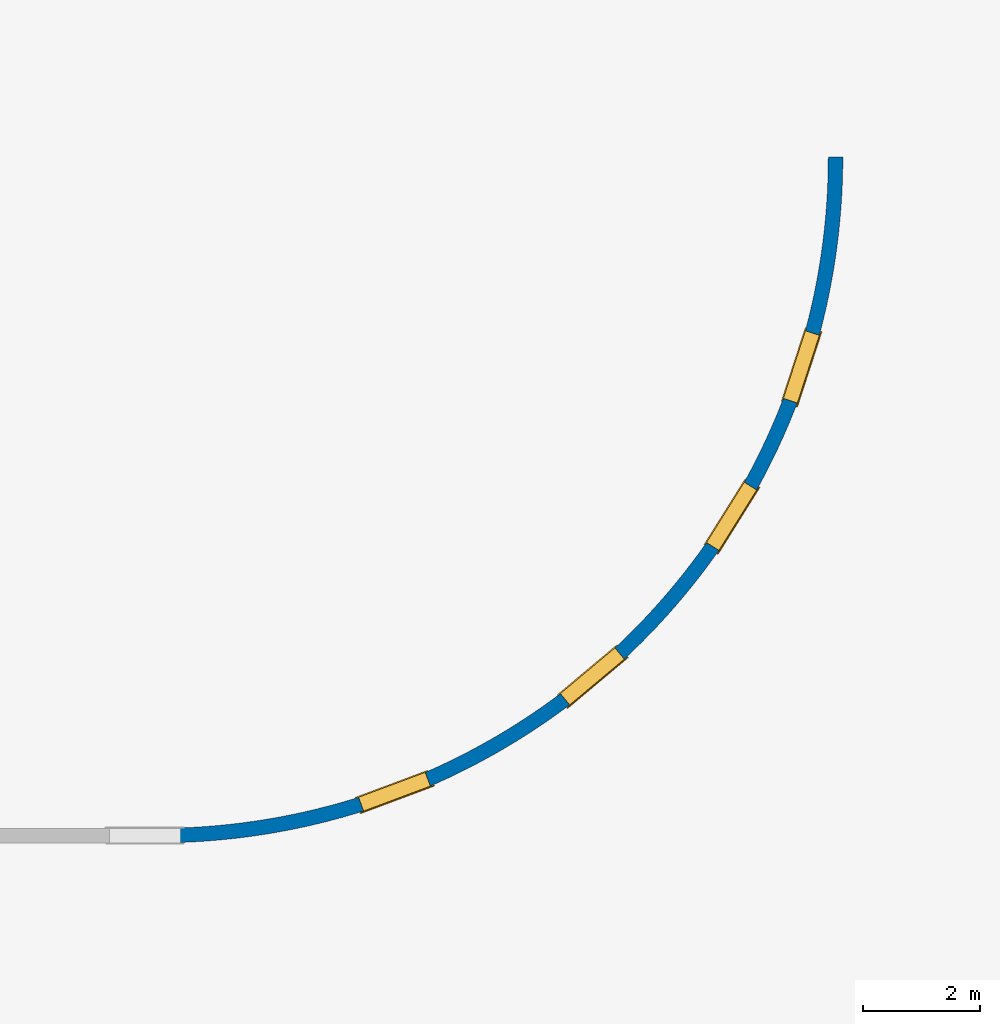
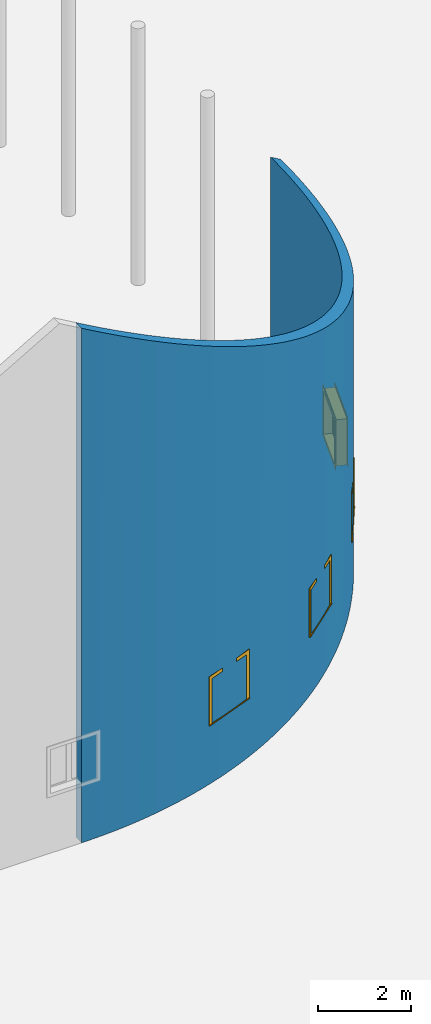
# One storey, part 9 of 39: 4 windows, 1 wall, 4 openings.
"""IFC2X3 building model written with IfcOpenShell, lengths in millimetres."""

from ifc_helpers import new_model, entity, si_unit, converted_unit, derived_unit, direction, frame, frame_2d, origin, origin_2d_with_axis, place, context, subcontext, project, spatial, polyline, circle_curve, parameter, trimmed, segment, composite_curve, rectangle, outline, extrude, clip, bounded_halfspace, source, transform, mapped, material, material_list, layer, layer_set, layer_usage, type_object, type_shapes, element, fill, save


model = new_model("IFC2X3")

# Units and contexts
model_context = context("Model", 3, precision=1e-06, world=origin(), true_north=direction((2.0, 6.12303176911189e-17, 1.0)))
context_of_model = context(None, 3, precision=1e-06, world=origin(), true_north=direction((2.0, 6.12303176911189e-17, 1.0)))
body_context = subcontext(model_context, "Body", "Model", "MODEL_VIEW")
ifc_project = project(units=[si_unit("LENGTHUNIT", "METRE", prefix="MILLI"), si_unit("AREAUNIT", "SQUARE_METRE", prefix="MILLI"), si_unit("VOLUMEUNIT", "CUBIC_METRE", prefix="MILLI"), converted_unit("PLANEANGLEUNIT", "DEGREE", entity("IfcRatioMeasure", 0.0174532925199433), si_unit("PLANEANGLEUNIT", "RADIAN"), dimensions=[0, 0, 0, 0, 0, 0, 0]), si_unit("MASSUNIT", "GRAM", prefix="KILO"), si_unit("TIMEUNIT", "SECOND"), si_unit("THERMODYNAMICTEMPERATUREUNIT", "KELVIN"), derived_unit("THERMALTRANSMITTANCEUNIT", [(si_unit("MASSUNIT", "GRAM", prefix="KILO"), 1), (si_unit("THERMODYNAMICTEMPERATUREUNIT", "KELVIN"), -1), (si_unit("TIMEUNIT", "SECOND"), -3)]), derived_unit("VOLUMETRICFLOWRATEUNIT", [(si_unit("LENGTHUNIT", "METRE"), 3), (si_unit("TIMEUNIT", "SECOND"), -1)])], contexts=[model_context, context_of_model])

# Site, building, storey
site_placement = place(None, origin())
site = spatial("IfcSite", under=ifc_project, at=site_placement, CompositionType="ELEMENT")
building_placement = place(site_placement, origin())
building = spatial("IfcBuilding", under=site, at=building_placement, CompositionType="ELEMENT")
storey_placement = place(building_placement, frame((0.0, 0.0, 4000.0)))
storey = spatial("IfcBuildingStorey", under=building, at=storey_placement, Name="Level 2", CompositionType="ELEMENT", Elevation=4000.0)

# Wall, openings, windows
ifc_material_1 = material(Name="Concrete - Cast In Situ")
ifc_layer = layer(ifc_material_1, 250.0)
ifc_layer_set = layer_set([ifc_layer], Name="Basic Wall:Structure wall")
ifc_layer_usage = layer_usage(ifc_layer_set, "AXIS2", "NEGATIVE", 125.0)
wall_type = type_object("IfcWallType", Name="Basic Wall:Structure wall", PredefinedType="STANDARD", material=ifc_layer_set)
wall_placement = place(storey_placement, frame((-80947.4247632614, -15130.5876773198, 362.0), z_axis=(0.0, 0.0, 1.0), x_axis=(-1.0, 0.0, 0.0)))
wall = element("IfcWallStandardCase", 1, at=wall_placement, inside=storey, type_object=wall_type, material=ifc_layer_usage, Name="Basic Wall:Structure wall", ObjectType="Basic Wall:Structure wall", context=body_context, shape_type="Clipping", body=[
    clip(extrude(outline(composite_curve([segment(trimmed(circle_curve(frame_2d((0.0, -11625.0), x_axis=(1.0, 0.0)), 11500.0), [parameter(90.0000000000001)], [parameter(180.0)], True, "PARAMETER"), False, "CONTINUOUS"), segment(polyline([(0.0, -125.0), (0.0, 125.0)]), True, "CONTINUOUS"), segment(trimmed(circle_curve(frame_2d((0.0, -11625.0), x_axis=(1.0, 0.0)), 11750.0), [parameter(90.0000000000001)], [parameter(180.0)], True, "PARAMETER"), True, "CONTINUOUS"), segment(polyline([(-11750.0, -11625.0), (-11500.0, -11625.0)]), True, "CONTINUOUS")], self_intersect=False)), origin(), (0.0, 0.0, 1.0), 13566.2032302757), bounded_halfspace(frame((-11500.0, -11625.0, 6926.67513459512), z_axis=(-0.499999999999996, 0.0, 0.866025403784441), x_axis=(0.0, -1.0, 0.0)), False, frame((-11500.0, -11625.0, 6926.67513459512)), composite_curve([segment(trimmed(circle_curve(frame_2d((11500.0, 0.0), x_axis=(-1.0, 0.0)), 11500.0), [parameter(270.0)], [parameter(1.01777749806833e-13)], True, "PARAMETER"), False, "CONTINUOUS"), segment(polyline([(11500.0, 11500.0), (11500.0, 11750.0)]), True, "CONTINUOUS"), segment(trimmed(circle_curve(frame_2d((11500.0, 0.0), x_axis=(1.0, 0.0)), 11750.0), [parameter(90.0000000000002)], [parameter(180.0)], True, "PARAMETER"), True, "CONTINUOUS"), segment(polyline([(-250.0, 0.0), (0.0, 0.0)]), True, "CONTINUOUS")], self_intersect=False))),
])
opening_1_placement = place(wall_placement, frame((-11093.7710030347, -8655.39082614288, 1553.0)))
opening_1 = element("IfcOpeningElement", 2, at=opening_1_placement, cuts=wall, Name="M_Casement Dbl with Trim:1220 x 1220mm:1220 x 1220mm:1", ObjectType="Opening", context=body_context, shape_type="SweptSolid", body=[
    extrude(rectangle(XDim=1220.0, YDim=1220.0, at=frame_2d((610.0, 610.0), x_axis=(-1.0, 0.0))), frame((0.0, 0.0, 0.0), z_axis=(-0.950891951006566, 0.309523016124694, 0.0), x_axis=(0.0, 0.0, 1.0)), (0.0, 0.0, 1.0), 266.687395378802),
])
opening_2_placement = place(wall_placement, frame((-10047.4754854389, -6062.75494222562, 1553.0)))
opening_2 = element("IfcOpeningElement", 3, at=opening_2_placement, cuts=wall, Name="M_Casement Dbl with Trim:1220 x 1220mm:1220 x 1220mm:1", ObjectType="Opening", context=body_context, shape_type="SweptSolid", body=[
    extrude(rectangle(XDim=1220.0, YDim=1220.0, at=frame_2d((610.0, 610.0), x_axis=(-1.0, 0.0))), frame((0.0, 0.0, 0.0), z_axis=(-0.847923288159283, 0.530118946461216, 0.0), x_axis=(0.0, 0.0, 1.0)), (0.0, 0.0, 1.0), 266.687395378802),
])
opening_3_placement = place(wall_placement, frame((-7833.9121675861, -3227.37212876297, 1553.0)))
opening_3 = element("IfcOpeningElement", 4, at=opening_3_placement, cuts=wall, Name="M_Casement Dbl with Trim:1220 x 1220mm:1220 x 1220mm:1", ObjectType="Opening", context=body_context, shape_type="SweptSolid", body=[
    extrude(rectangle(XDim=1220.0, YDim=1220.0, at=frame_2d((610.0, 610.0), x_axis=(-1.0, 0.0))), frame((0.0, 0.0, 0.0), z_axis=(-0.642335534675915, 0.766423551890603, 0.0), x_axis=(0.0, 0.0, 1.0)), (0.0, 0.0, 1.0), 266.687395378802),
])
opening_4_placement = place(wall_placement, frame((-4588.23789287691, -1097.01791644764, 1553.0)))
opening_4 = element("IfcOpeningElement", 5, at=opening_4_placement, cuts=wall, Name="M_Casement Dbl with Trim:1220 x 1220mm:1220 x 1220mm:1", ObjectType="Opening", context=body_context, shape_type="SweptSolid", body=[
    extrude(rectangle(XDim=1220.0, YDim=1220.0, at=frame_2d((610.0, 610.0), x_axis=(-1.0, 0.0))), frame((0.0, 0.0, 0.0), z_axis=(-0.35026437395302, 0.936650878577124, 0.0), x_axis=(0.0, 0.0, 1.0)), (0.0, 0.0, 1.0), 266.687395378802),
])
ifc_material_2 = material(Name="Glass")
ifc_material_3 = material(Name="Sash")
ifc_material_4 = material(Name="Trim")
ifc_material_list_1 = material_list([ifc_material_2, ifc_material_3, ifc_material_4])
ifc_material_list_2 = material_list([ifc_material_2, ifc_material_3, ifc_material_4])
window_style = type_object("IfcWindowStyle", Name="1220 x 1220mm", ConstructionType="NOTDEFINED", OperationType="NOTDEFINED", ParameterTakesPrecedence=False, Sizeable=False, material=ifc_material_list_2)
shared_shape = source(origin(), body_context, "Body", "SweptSolid", [
    extrude(rectangle(XDim=12.7, YDim=482.999999999998, at=origin_2d_with_axis()), frame((915.0, 208.775, 63.5000000000002), z_axis=(0.0, 0.0, 1.0), x_axis=(0.0, -1.0, 0.0)), (0.0, 0.0, 1.0), 1093.0),
    extrude(outline(polyline([(-285.949999999999, -590.950000000002), (285.949999999999, -590.950000000002), (285.949999999999, 590.950000000003), (-285.949999999999, 590.950000000003), (-285.949999999999, -590.950000000002)]), holes=[polyline([(-241.499999999998, -546.500000000003), (-241.499999999998, 546.500000000002), (241.5, 546.500000000002), (241.5, -546.500000000003), (-241.499999999998, -546.500000000003)])]), frame((915.0, 186.55, 610.0), z_axis=(0.0, 1.0, 0.0), x_axis=(1.0, 0.0, 0.0)), (0.0, 0.0, 1.0), 44.45),
    extrude(rectangle(XDim=25.7, YDim=1359.89999999999, at=frame_2d((-1.68753899743024e-14, 0.0), x_axis=(1.0, 0.0))), frame((610.0, 262.85, 0.0), z_axis=(0.0, 0.0, 1.0), x_axis=(0.0, -1.0, 0.0)), (0.0, 0.0, 1.0), 19.0500000000014),
    extrude(outline(polyline([(-568.700000000007, 590.949999999995), (613.200000000007, 590.949999999995), (613.200000000007, 679.949999999994), (-657.700000000005, 679.949999999994), (-657.700000000005, -679.949999999993), (613.200000000006, -679.949999999993), (613.200000000006, -590.949999999995), (-568.700000000007, -590.949999999995), (-568.700000000007, 590.949999999995)])), frame((610.0, 250.0, 632.250000000007), z_axis=(0.0, 1.0, 0.0), x_axis=(0.0, 0.0, -1.0)), (0.0, 0.0, 1.0), 13.0),
    extrude(outline(polyline([(-667.25000000001, -667.249999999998), (667.25000000001, -667.249999999998), (667.25000000001, 667.249999999998), (-667.25000000001, 667.249999999998), (-667.25000000001, -667.249999999998)]), holes=[polyline([(-578.250000000011, -578.250000000001), (-578.250000000011, 578.249999999997), (578.24999999999, 578.249999999997), (578.24999999999, -578.250000000001), (-578.250000000011, -578.250000000001)])]), frame((610.0, -19.0, 610.0), z_axis=(0.0, 1.0, 0.0), x_axis=(0.0, 0.0, -1.0)), (0.0, 0.0, 1.0), 19.0),
    extrude(rectangle(XDim=12.7, YDim=482.999999999998, at=frame_2d((1.68753899743024e-14, 4.2632564145606e-14), x_axis=(1.0, 0.0))), frame((305.0, 208.775, 63.4999999999994), z_axis=(0.0, 0.0, 1.0), x_axis=(0.0, 1.0, 0.0)), (0.0, 0.0, 1.0), 1093.0),
    extrude(outline(polyline([(-285.949999999999, -590.950000000002), (285.949999999999, -590.950000000002), (285.949999999999, 590.950000000002), (-285.949999999999, 590.950000000002), (-285.949999999999, -590.950000000002)]), holes=[polyline([(-241.499999999999, -546.500000000003), (-241.499999999999, 546.500000000001), (241.499999999999, 546.500000000001), (241.499999999999, -546.500000000003), (-241.499999999999, -546.500000000003)])]), frame((305.0, 186.55, 610.0), z_axis=(0.0, 1.0, 0.0), x_axis=(1.0, 0.0, 0.0)), (0.0, 0.0, 1.0), 44.45),
    extrude(outline(polyline([(-610.0, -610.0), (610.0, -610.0), (610.0, 610.0), (-610.0, 610.0), (-610.0, -610.0)]), holes=[polyline([(-578.25, -578.250000000001), (-578.25, 578.25), (578.249999999997, 578.25), (578.249999999997, -578.250000000001), (-578.25, -578.250000000001)])]), frame((610.0, 0.0, 610.0), z_axis=(0.0, 1.0, 0.0), x_axis=(1.0, 0.0, 0.0)), (0.0, 0.0, 1.0), 186.55),
    extrude(outline(polyline([(-610.0, -610.0), (610.0, -610.0), (610.0, 610.0), (-610.0, 610.0), (-610.0, -610.0)]), holes=[polyline([(-590.950000000002, -590.949999999996), (-590.950000000002, 590.95), (590.950000000003, 590.95), (590.950000000003, -590.949999999996), (-590.950000000002, -590.949999999996)])]), frame((610.0, 186.55, 610.0), z_axis=(0.0, 1.0, 0.0), x_axis=(0.0, 0.0, -1.0)), (0.0, 0.0, 1.0), 63.45),
    extrude(rectangle(XDim=63.5, YDim=38.0999999999998, at=frame_2d((-8.88178419700125e-15, 0.0), x_axis=(1.0, 0.0))), frame((610.0, 218.3, 19.0499999999995), z_axis=(0.0, 0.0, 1.0), x_axis=(0.0, 1.0, 0.0)), (0.0, 0.0, 1.0), 1181.90000000001),
])
type_shapes(window_style, [shared_shape])
window_1_placement = place(opening_1_placement, frame((-15.2288511867373, 4.95711415628557, 0.0), z_axis=(0.0, 0.0, 1.0), x_axis=(0.309523016124694, 0.950891951006566, 0.0)))
window_1 = element("IfcWindow", 6, at=window_1_placement, inside=storey, type_object=window_style, material=ifc_material_list_1, Name="M_Casement Dbl with Trim:1220 x 1220mm", ObjectType="1220 x 1220mm", OverallHeight=1220.0, OverallWidth=1220.0, context=body_context, shape_type="MappedRepresentation", body=[
    mapped(shared_shape, transform((0.0, 0.0, 0.0), scale=1.0)),
])
fill(opening_1, window_1)
ifc_material_list_3 = material_list([ifc_material_2, ifc_material_3, ifc_material_4])
window_2_placement = place(opening_2_placement, frame((-13.5797737687099, 8.49003142615948, 0.0), z_axis=(0.0, 0.0, 1.0), x_axis=(0.530118946461216, 0.847923288159283, 0.0)))
window_2 = element("IfcWindow", 7, at=window_2_placement, inside=storey, type_object=window_style, material=ifc_material_list_3, Name="M_Casement Dbl with Trim:1220 x 1220mm", ObjectType="1220 x 1220mm", OverallHeight=1220.0, OverallWidth=1220.0, context=body_context, shape_type="MappedRepresentation", body=[
    mapped(shared_shape, transform((0.0, 0.0, 0.0), scale=1.0)),
])
fill(opening_2, window_2)
ifc_material_list_4 = material_list([ifc_material_2, ifc_material_3, ifc_material_4])
window_3_placement = place(opening_3_placement, frame((-10.2872174479708, 12.2745283577151, 0.0), z_axis=(0.0, 0.0, 1.0), x_axis=(0.766423551890603, 0.642335534675915, 0.0)))
window_3 = element("IfcWindow", 8, at=window_3_placement, inside=storey, type_object=window_style, material=ifc_material_list_4, Name="M_Casement Dbl with Trim:1220 x 1220mm", ObjectType="1220 x 1220mm", OverallHeight=1220.0, OverallWidth=1219.99999999999, context=body_context, shape_type="MappedRepresentation", body=[
    mapped(shared_shape, transform((0.0, 0.0, 0.0), scale=1.0)),
])
fill(opening_3, window_3)
ifc_material_list_5 = material_list([ifc_material_2, ifc_material_3, ifc_material_4])
window_4_placement = place(opening_4_placement, frame((-5.60960056640033, 15.0007756703344, 0.0), z_axis=(0.0, 0.0, 1.0), x_axis=(0.936650878577124, 0.35026437395302, 0.0)))
window_4 = element("IfcWindow", 9, at=window_4_placement, inside=storey, type_object=window_style, material=ifc_material_list_5, Name="M_Casement Dbl with Trim:1220 x 1220mm", ObjectType="1220 x 1220mm", OverallHeight=1220.0, OverallWidth=1220.0, context=body_context, shape_type="MappedRepresentation", body=[
    mapped(shared_shape, transform((0.0, 0.0, 0.0), scale=1.0)),
])
fill(opening_4, window_4)

save(model, "model.ifc")
